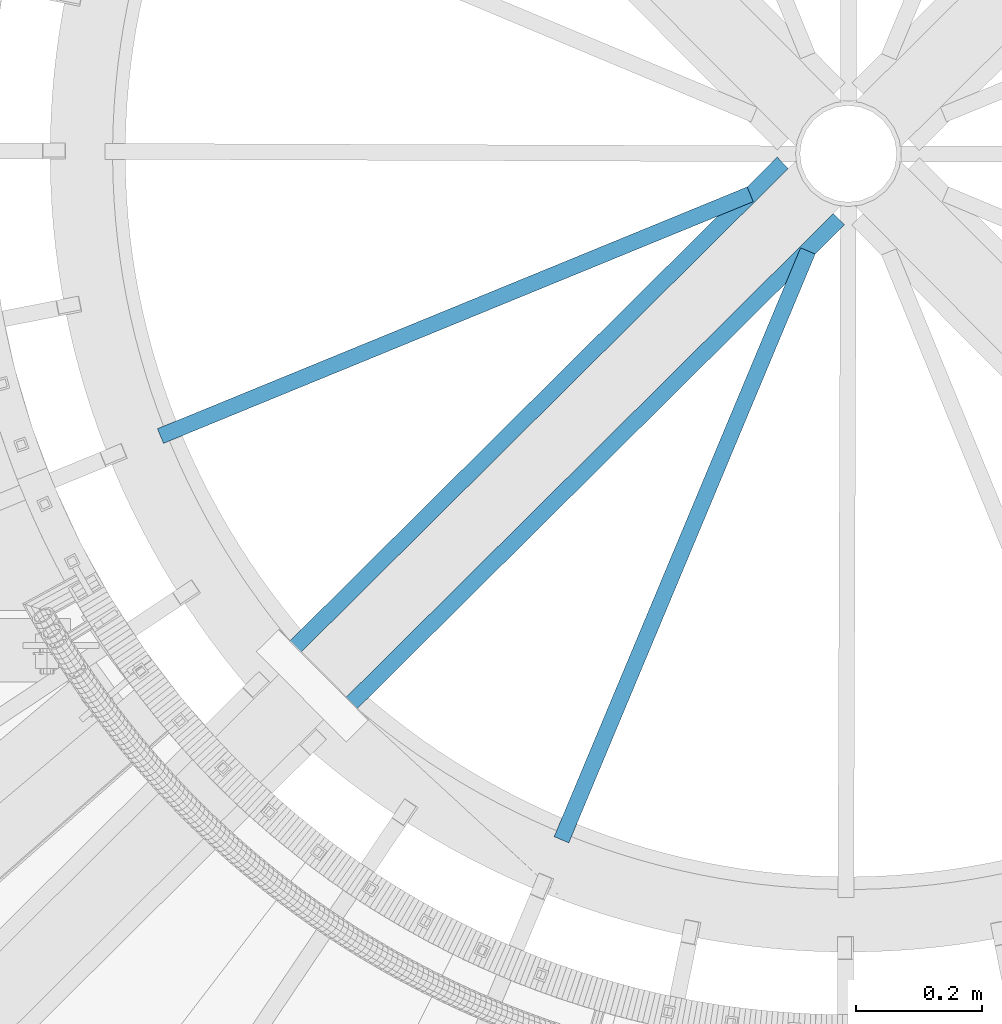
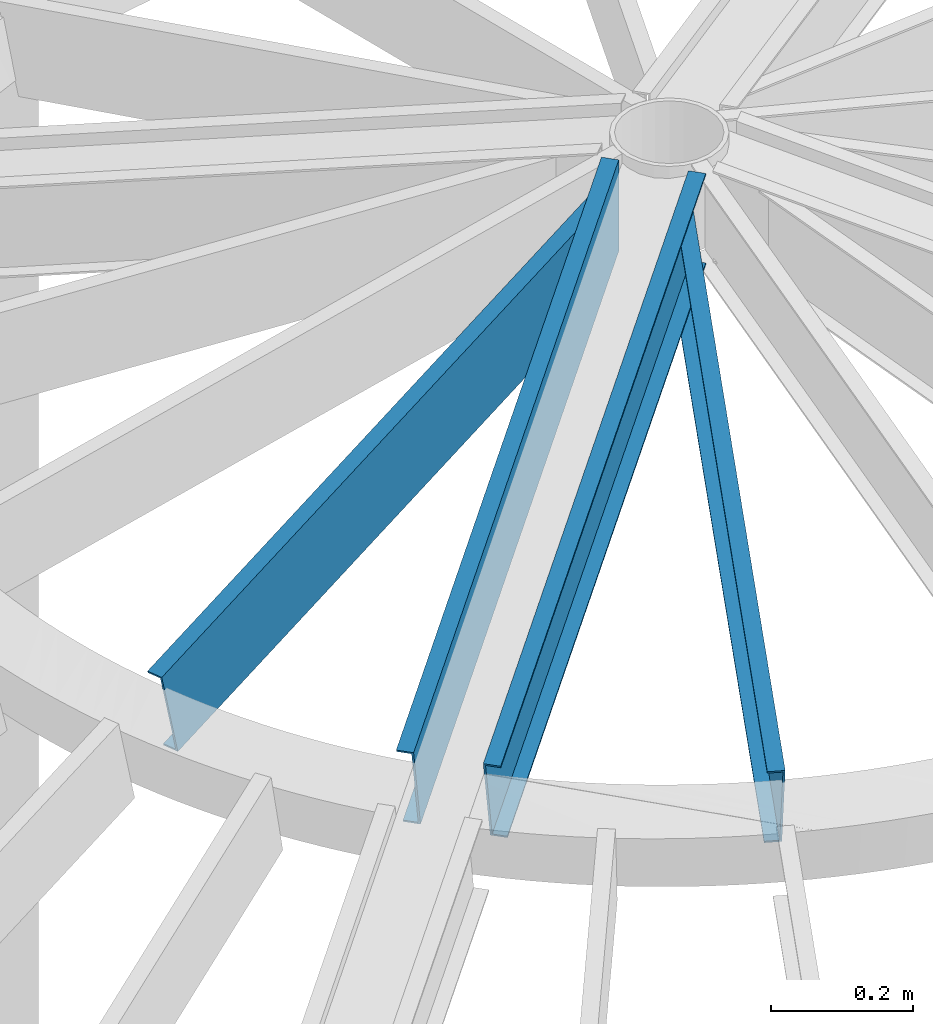
# One storey, part 347 of 975: 4 beams.
"""IFC2X3 building model written with IfcOpenShell, lengths in millimetres."""

from ifc_helpers import new_model, si_unit, frame, origin_with_axes, place, context, subcontext, project, spatial, faceted_brep, material, type_object, element, save


model = new_model("IFC2X3")

# Units and contexts
model_context = context("Model", 3, precision=1e-05, world=origin_with_axes())
body_context = subcontext(model_context, "Body", "Model", "MODEL_VIEW")
ifc_project = project(units=[si_unit("LENGTHUNIT", "METRE", prefix="MILLI"), si_unit("AREAUNIT", "SQUARE_METRE"), si_unit("VOLUMEUNIT", "CUBIC_METRE"), si_unit("MASSUNIT", "GRAM", prefix="KILO"), si_unit("TIMEUNIT", "SECOND"), si_unit("PLANEANGLEUNIT", "RADIAN"), si_unit("SOLIDANGLEUNIT", "STERADIAN"), si_unit("THERMODYNAMICTEMPERATUREUNIT", "DEGREE_CELSIUS"), si_unit("LUMINOUSINTENSITYUNIT", "LUMEN")], contexts=[model_context])

# Site, building, storey
site_placement = place(None, origin_with_axes())
site = spatial("IfcSite", under=ifc_project, at=site_placement, CompositionType="ELEMENT")
building_placement = place(site_placement, origin_with_axes())
building = spatial("IfcBuilding", under=site, at=building_placement, Name="Undefined", CompositionType="ELEMENT")
storey_placement = place(building_placement, origin_with_axes())
storey = spatial("IfcBuildingStorey", under=building, at=storey_placement, Name="Undefined", CompositionType="ELEMENT", Elevation=0.0)

# Beams
ifc_material = material(Name="STEEL/Zero_Density")
beam_type = type_object("IfcBeamType", PredefinedType="NOTDEFINED")
beam_1_placement = place(storey_placement, frame((34673.9967125499, 3378.42341614582, 9185.06096723024), z_axis=(-0.224418098973874, -0.0919951519892898, 0.970140922167197), x_axis=(-0.89764757448781, -0.367970434790039, -0.242541936861608)))
element("IfcBeam", 1, at=beam_1_placement, inside=storey, type_object=beam_type, material=ifc_material, Name="STUD", context=body_context, shape_type="Brep", body=[
    faceted_brep([(1134.70057945789, -12.6999999990348, 76.200000000108), (1134.70057945789, -12.6999999990367, 73.0250000001097), (1134.70057945792, 9.52500000095824, 73.025000000097), (1134.70057945806, 9.52500000092914, -73.0249999998405), (1134.70057945804, -12.6999999990658, -73.0249999998296), (1134.70057945805, -12.6999999990658, -76.1999999998279), (1134.70057945806, 12.7000000009302, -76.1999999998443), (1134.70057945791, 12.700000000963, 76.2000000000953), (125.830470330438, -12.699999999908, -76.199999999948), (125.830470360648, 12.700000000088, -76.1999999999616), (87.7294169224115, 12.7000000000862, 76.1999999999744), (87.7294168921944, -12.699999999908, 76.1999999999871), (88.5231888388298, -12.6999999999098, 73.0249999999878), (88.5231888652634, 9.52500000008513, 73.024999999976), (125.036698410244, 9.52500000008877, -73.0249999999596), (125.03669838381, -12.6999999999061, -73.0249999999487)], [[[0, 1, 2, 3, 4, 5, 6, 7]], [[6, 5, 8, 9]], [[7, 6, 9, 10]], [[0, 7, 10, 11]], [[1, 0, 11, 12]], [[2, 1, 12, 13]], [[3, 2, 13, 14]], [[4, 3, 14, 15]], [[5, 4, 15, 8]], [[14, 13, 12, 11, 10, 9, 8, 15]]]),
])
beam_2_placement = place(storey_placement, frame((34709.5202483303, 3343.01518198953, 9185.06096723024), z_axis=(-0.0936371633068046, -0.223737955733079, 0.970140922140818), x_axis=(-0.374538296949224, -0.894927076878677, -0.242541936967119)))
element("IfcBeam", 2, at=beam_2_placement, inside=storey, type_object=beam_type, material=ifc_material, Name="STUD", context=body_context, shape_type="Brep", body=[
    faceted_brep([(1134.70057945789, -12.6999999990348, 76.200000000108), (1134.70057945789, -12.6999999990367, 73.0250000001097), (1134.70057945792, 9.52500000095824, 73.025000000097), (1134.70057945806, 9.52500000092914, -73.0249999998405), (1134.70057945804, -12.6999999990658, -73.0249999998296), (1134.70057945805, -12.6999999990658, -76.1999999998279), (1134.70057945806, 12.7000000009302, -76.1999999998443), (1134.70057945791, 12.700000000963, 76.2000000000953), (124.283917888468, -12.7000000001171, -76.1999999999734), (124.283917926634, 12.6999999999316, -76.1999999999898), (86.1828643469635, 12.6999999999425, 76.200000000108), (86.1828643088047, -12.7000000001062, 76.2000000001244), (86.9766362583796, -12.7000000001099, 73.0250000001215), (86.9766362917726, 9.52499999993961, 73.0250000001079), (123.490145972286, 9.52499999993233, -73.0249999999851), (123.490145938893, -12.7000000001171, -73.0249999999724)], [[[0, 1, 2, 3, 4, 5, 6, 7]], [[6, 5, 8, 9]], [[7, 6, 9, 10]], [[0, 7, 10, 11]], [[1, 0, 11, 12]], [[2, 1, 12, 13]], [[3, 2, 13, 14]], [[4, 3, 14, 15]], [[5, 4, 15, 8]], [[14, 13, 12, 11, 10, 9, 8, 15]]]),
])
beam_3_placement = place(storey_placement, frame((34643.170153205, 3402.31882295273, 9185.06096723024), z_axis=(-0.17213026717781, -0.170873527176511, 0.970140922150774), x_axis=(-0.688502032793625, -0.683475207795133, -0.242541936927299)))
element("IfcBeam", 3, at=beam_3_placement, inside=storey, type_object=beam_type, material=ifc_material, Name="STUD", context=body_context, shape_type="Brep", body=[
    faceted_brep([(1134.70057945789, -12.6999999990348, 76.200000000108), (1134.70057945789, -12.6999999990367, 73.0250000001097), (1134.70057945792, 9.52500000095824, 73.025000000097), (1134.70057945806, 9.52500000092914, -73.0249999998405), (1134.70057945804, -12.6999999990658, -73.0249999998296), (1134.70057945805, -12.6999999990658, -76.1999999998279), (1134.70057945806, 12.7000000009302, -76.1999999998443), (1134.70057945791, 12.700000000963, 76.2000000000953), (38.1010538948394, -12.7000000000157, -76.1999999999643), (38.1010539016352, 12.6999999999862, -76.1999999999662), (1.96450855582952e-10, 12.7000000001644, 76.2000000001021), (1.74622982740402e-10, -12.6999999998661, 76.2000000000985), (0.79377234254207, -12.699999999993, 73.0249999999905), (0.793772348486527, 9.52500000000873, 73.0249999999905), (37.3072819528606, 9.52499999998645, -73.0249999999669), (37.3072819469235, -12.7000000000148, -73.0249999999651)], [[[0, 1, 2, 3, 4, 5, 6, 7]], [[6, 5, 8, 9]], [[7, 6, 9, 10]], [[0, 7, 10, 11]], [[1, 0, 11, 12]], [[2, 1, 12, 13]], [[3, 2, 13, 14]], [[4, 3, 14, 15]], [[5, 4, 15, 8]], [[14, 13, 12, 11, 10, 9, 8, 15]]]),
])
beam_4_placement = place(storey_placement, frame((33951.3525912593, 2536.69529308342, 8909.8484911832), z_axis=(-0.17213026717781, -0.170873527176511, 0.970140922150774), x_axis=(0.688502112820797, 0.683475127155154, 0.242541936995531)))
element("IfcBeam", 4, at=beam_4_placement, inside=storey, type_object=beam_type, material=ifc_material, Name="STUD", context=body_context, shape_type="Brep", body=[
    faceted_brep([(-1.92812876775861e-10, -12.7000000001717, -76.2000000001003), (-1.81898940354586e-10, -12.7000000001608, -73.0250000000965), (-1.60071067512035e-10, 9.52499999986321, -73.0250000000938), (1.89174897968769e-10, 9.52500000015425, 73.0250000000974), (1.67347025126219e-10, -12.6999999998698, 73.0250000000947), (1.74622982740402e-10, -12.6999999998661, 76.2000000000985), (1.96450855582952e-10, 12.7000000001644, 76.2000000001021), (-1.67347025126219e-10, 12.6999999998588, -76.2000000000985), (1134.70057945789, -12.6999999990348, 76.200000000108), (1134.70057945791, 12.700000000963, 76.2000000000953), (1096.59952564954, 12.6999999982763, -76.1999999995651), (1096.59952565276, -12.7000000017433, -76.1999999995523), (1097.39329760113, -12.700000001747, -73.0249999995513), (1097.39329759832, 9.52499999827342, -73.0249999995613), (1133.90680722362, 9.5249999982334, 73.0250000005217), (1133.90680722643, -12.7000000017833, 73.0250000005308)], [[[0, 1, 2, 3, 4, 5, 6, 7]], [[8, 9, 6, 5]], [[7, 6, 9, 10]], [[0, 7, 10, 11]], [[1, 0, 11, 12]], [[2, 1, 12, 13]], [[3, 2, 13, 14]], [[4, 3, 14, 15]], [[5, 4, 15, 8]], [[14, 13, 12, 11, 10, 9, 8, 15]]]),
])

save(model, "model.ifc")
